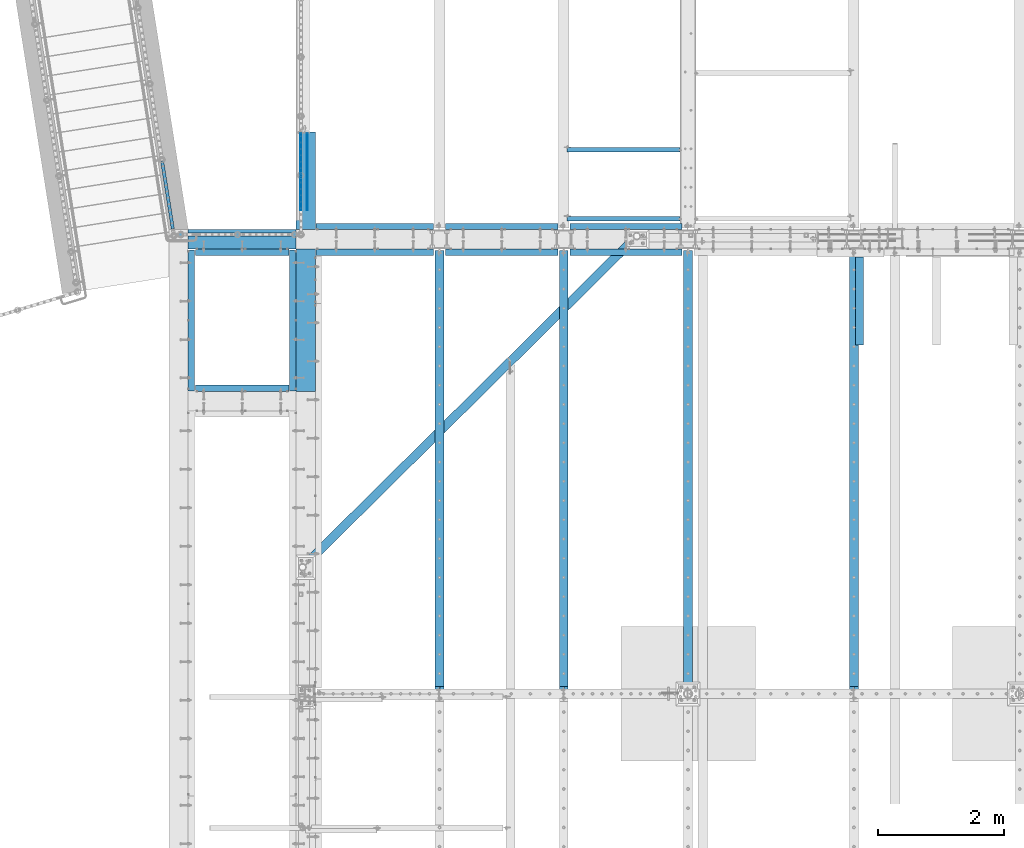
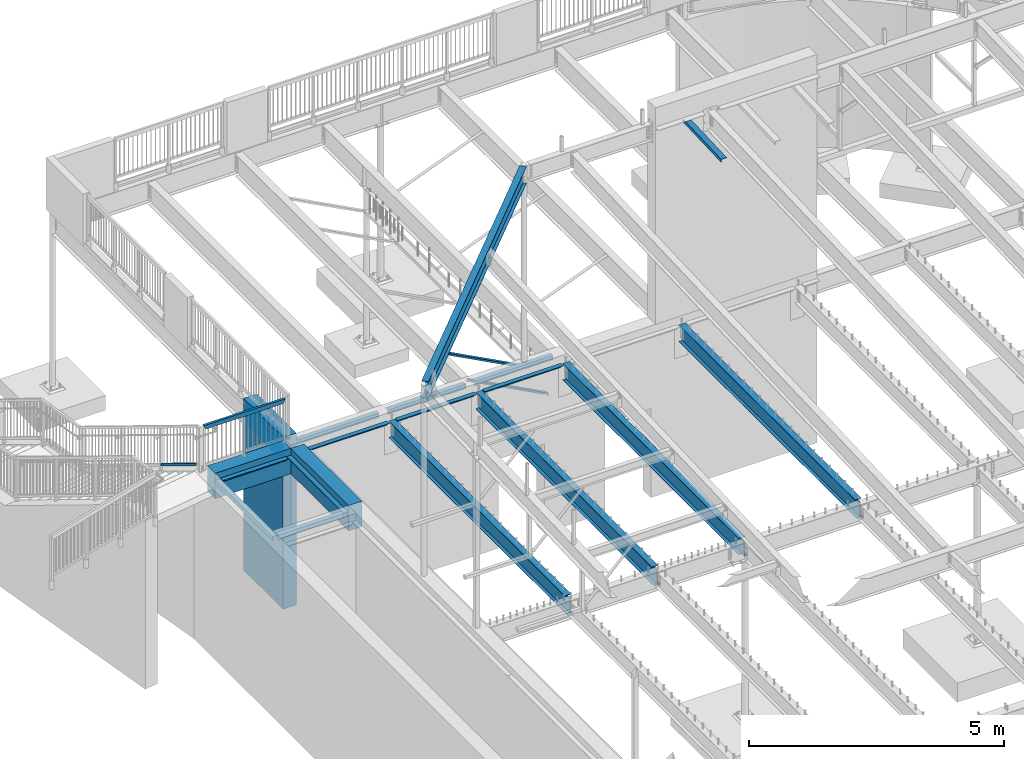
# One storey, part 319 of 975: 34 beams, 1 member.
"""IFC2X3 building model written with IfcOpenShell, lengths in millimetres."""

from ifc_helpers import new_model, si_unit, frame, origin_with_axes, place, context, subcontext, project, spatial, faceted_brep, material, type_object, element, save


model = new_model("IFC2X3")

# Units and contexts
model_context = context("Model", 3, precision=1e-05, world=origin_with_axes())
body_context = subcontext(model_context, "Body", "Model", "MODEL_VIEW")
ifc_project = project(units=[si_unit("LENGTHUNIT", "METRE", prefix="MILLI"), si_unit("AREAUNIT", "SQUARE_METRE"), si_unit("VOLUMEUNIT", "CUBIC_METRE"), si_unit("MASSUNIT", "GRAM", prefix="KILO"), si_unit("TIMEUNIT", "SECOND"), si_unit("PLANEANGLEUNIT", "RADIAN"), si_unit("SOLIDANGLEUNIT", "STERADIAN"), si_unit("THERMODYNAMICTEMPERATUREUNIT", "DEGREE_CELSIUS"), si_unit("LUMINOUSINTENSITYUNIT", "LUMEN")], contexts=[model_context])

# Site, building, storey
site_placement = place(None, origin_with_axes())
site = spatial("IfcSite", under=ifc_project, at=site_placement, CompositionType="ELEMENT")
building_placement = place(site_placement, origin_with_axes())
building = spatial("IfcBuilding", under=site, at=building_placement, Name="Undefined", CompositionType="ELEMENT")
storey_placement = place(building_placement, origin_with_axes())
storey = spatial("IfcBuildingStorey", under=building, at=storey_placement, Name="Undefined", CompositionType="ELEMENT", Elevation=0.0)

# Beams
ifc_material_1 = material(Name="STEEL/A36")
beam_type_1 = type_object("IfcBeamType", Name="L3X3X3/16", PredefinedType="NOTDEFINED")
for number, where, z_axis, x_axis, name in (
    (1, (8064.5, 22016.24375, 2870.2), (-0.999999999999998, 6.90000001668524e-08, 0.0), (0.0, 0.0, 1.0), "ANGLE"),
    (2, (8064.5, 20924.04375, 2870.2), (-0.999999999999998, 6.90000001668524e-08, 0.0), (0.0, 0.0, 1.0), "ANGLE"),
):
    element("IfcBeam", number, at=place(storey_placement, frame(where, z_axis=z_axis, x_axis=x_axis)), inside=storey, type_object=beam_type_1, material=ifc_material_1, Name=name, ObjectType="L3X3X3/16", context=body_context, shape_type="Brep", body=[
        faceted_brep([(46.1799589858119, 38.0999999999985, 38.1000000000004), (46.1799589858119, 33.3375000000015, 38.1000000000004), (972.720343066658, 33.3375000000015, 1789.57301067668), (972.720343066658, 38.0999999999985, 1789.57301067668), (26.0603826014149, 38.0999999999985, 0.0672324894812846), (26.0603826014149, 33.3375000000015, 0.0672324894812846), (89.2065642251332, 38.0999999999985, -33.3374999984389), (89.2065642251332, 33.3375000000015, -33.3374999984389), (1035.86652469034, 33.3375000000015, 1756.16827818882), (89.2065642281518, -38.0999999999985, -33.3374999999996), (1035.86652469042, -38.0999999999985, 1756.16827818877), (25.4000000000001, -38.0999999999985, -33.3374999999996), (25.4000000000001, -38.0999999999985, -38.1000000000004), (92.0750045776413, -38.0999999999985, -38.1000000000004), (1040.07627013201, -38.0999999999985, 1753.94129602291), (92.0750045776413, 38.0999999999985, -38.1000000000004), (25.4000000000001, 38.0999999999985, -38.1000000000004), (1040.07627013201, 38.0999999999985, 1753.94129602291), (25.4000000000001, 38.0999999999985, -33.337499282643), (25.4000000000001, 33.3375000000015, -33.3374999999996)], [[[0, 1, 2, 3]], [[1, 0, 4, 5]], [[5, 4, 6, 7]], [[1, 5, 7, 8, 2]], [[7, 9, 10, 8]], [[9, 11, 12, 13, 14, 10]], [[15, 13, 12, 16]], [[13, 15, 17, 14]], [[3, 2, 8, 10, 14, 17]], [[15, 16, 18, 6, 4, 0, 3, 17]], [[7, 6, 18, 19]], [[16, 12, 11, 19, 18]], [[9, 7, 19, 11]]]),
    ])

# Member
ifc_material_2 = material()
member_type = type_object("IfcMemberType", Name="HSS2X2X.188_TUBES", PredefinedType="NOTDEFINED")
member_placement = place(storey_placement, frame((64.2711378482237, 20753.3422070973, 4156.0636980397), z_axis=(0.987688352468583, 0.156434390074216, -6.09999983468464e-08), x_axis=(-0.136949714005939, 0.864666463037498, -0.48331840802096)))
element("IfcMember", 3, at=member_placement, inside=storey, type_object=member_type, material=ifc_material_2, Name="HANDRAIL", ObjectType="HSS2X2X.188_TUBES", context=body_context, shape_type="Brep", body=[
    faceted_brep([(1.22733805137614, 20.6375000000317, -20.6374999999935), (11.864264413236, -20.6375000000044, -20.6375000000012), (1260.85730620972, -20.6375000006847, -20.6375000002959), (1238.07006599417, 20.6374999993604, -20.6375000002859), (11.8642640556318, -20.6375000000298, 20.6374999999916), (1260.8573061982, -20.6375000007101, 20.637499999697), (1.2273376937701, 20.6375000000044, 20.6374999999994), (1238.07006598265, 20.6374999993313, 20.637499999707), (0.0, 25.3999999999724, -25.4000000000342), (0.0, 25.400000000016, 25.4000000000196), (1235.44076903337, 25.3999999993339, 25.3999999997081), (1235.44076904756, 25.3999999993666, -25.4000000002829), (13.0916016715055, -25.4000000000397, 25.3999999999892), (1263.48660314481, -25.4000000007181, 25.399999999695), (13.0916021116373, -25.4000000000051, -25.4000000000015), (1263.48660315901, -25.4000000006854, -25.4000000002961)], [[[0, 1, 2, 3]], [[1, 4, 5, 2]], [[4, 6, 7, 5]], [[6, 0, 3, 7]], [[8, 9, 10, 11]], [[9, 12, 13, 10]], [[12, 14, 15, 13]], [[14, 8, 11, 15]], [[13, 15, 11, 10], [5, 7, 3, 2]], [[14, 12, 9, 8], [6, 4, 1, 0]]]),
])

# Beams
beam_type_2 = type_object("IfcBeamType", Name="HSS2X4X.188_TUBES", PredefinedType="NOTDEFINED")
beam_1_placement = place(storey_placement, frame((160.888332432286, 20672.4249713359, 5054.60000302264), z_axis=(0.0, 0.0, 1.0), x_axis=(1.0, 0.0, 0.0)))
element("IfcBeam", 4, at=beam_1_placement, inside=storey, type_object=beam_type_2, material=ifc_material_2, Name="HANDRAIL", ObjectType="HSS2X4X.188_TUBES", context=body_context, shape_type="Brep", body=[
    faceted_brep([(48.4187519319242, 20.6374999999716, -46.0375000000158), (48.4187519525875, -20.6375000000262, -46.0375000000158), (1806.21591102758, -20.6375000011067, -46.0375000006106), (1806.21591812686, 20.6374999988948, -46.0375000006106), (2.38125022328143, -20.6375000000007, 46.0374999999995), (1852.253417019, -20.6375000011321, 46.0374999993737), (2.38125020261811, 20.6375000000007, 46.0374999999995), (1852.25342411827, 20.6374999988693, 46.0374999993728), (50.8000020189868, 25.3999999999687, -50.8000000000166), (1.10786999130141e-07, 25.4000000000015, 50.8000000000011), (1854.63467524732, 25.3999999988628, 50.7999999993726), (1803.8346686361, 25.3999999988955, -50.8000000006105), (1.36218801571886e-07, -25.4000000000015, 50.8000000000011), (1854.63466650975, -25.4000000011365, 50.7999999993726), (50.8000020444186, -25.4000000000306, -50.8000000000166), (1803.83465989853, -25.4000000011038, -50.8000000006105)], [[[0, 1, 2, 3]], [[1, 4, 5, 2]], [[4, 6, 7, 5]], [[6, 0, 3, 7]], [[8, 9, 10, 11]], [[9, 12, 13, 10]], [[12, 14, 15, 13]], [[14, 8, 11, 15]], [[13, 15, 11, 10], [5, 7, 3, 2]], [[14, 12, 9, 8], [6, 4, 1, 0]]]),
])
beam_type_3 = type_object("IfcBeamType", Name="L4X4X5/16", PredefinedType="NOTDEFINED")
for number, where, z_axis, x_axis, name in (
    (5, (8134.35000000049, 20799.4249996637, 3886.2), (0.0, 1.0, 0.0), (-0.999999999999998, 6.90000001668524e-08, 0.0), "LEDGER_ANGLE"),
    (6, (6164.79172920556, 20799.4249996637, 3886.2), (0.0, 1.0, 0.0), (-0.999999999999998, 6.90000001668524e-08, 0.0), "LEDGER_ANGLE"),
):
    element("IfcBeam", number, at=place(storey_placement, frame(where, z_axis=z_axis, x_axis=x_axis)), inside=storey, type_object=beam_type_3, material=ifc_material_1, Name=name, ObjectType="L4X4X5/16", context=body_context, shape_type="Brep", body=[
        faceted_brep([(-1.90993887372315e-11, 50.8000000000002, -50.8), (2.00088834390044e-11, 50.8000000000002, 50.8), (1779.05827079733, 50.8000000000002, 50.7999999999993), (1779.05827079733, 50.8000000000002, -50.7999999999993), (2.00088834390044e-11, 42.8625000000002, 50.8), (1779.05827079733, 42.8625000000002, 50.7999999999993), (-1.63709046319127e-11, 42.8625000000002, -42.8625), (1779.05827079733, 42.8625000000002, -42.8624999999993), (-1.63709046319127e-11, -50.8000000000002, -42.8625), (1779.05827079733, -50.8000000000002, -42.8624999999993), (-1.90993887372315e-11, -50.8000000000002, -50.8), (1779.05827079733, -50.8000000000002, -50.7999999999993)], [[[0, 1, 2, 3]], [[1, 4, 5, 2]], [[4, 6, 7, 5]], [[6, 8, 9, 7]], [[8, 10, 11, 9]], [[10, 0, 3, 11]], [[5, 7, 9, 11, 3, 2]], [[10, 8, 6, 4, 1, 0]]]),
    ])
beam_2_placement = place(storey_placement, frame((4195.2334584078, 20799.4249996637, 3886.2), z_axis=(0.0, 1.0, 0.0), x_axis=(-0.999999999999998, 6.90000001668524e-08, 0.0)))
element("IfcBeam", 7, at=beam_2_placement, inside=storey, type_object=beam_type_3, material=ifc_material_1, Name="LEDGER_ANGLE", ObjectType="L4X4X5/16", context=body_context, shape_type="Brep", body=[
    faceted_brep([(-1.90993887372315e-11, 50.8000000000002, -50.8), (2.00088834390044e-11, 50.8000000000002, 50.8), (1861.60845841014, 50.8000000000002, 50.7999999999993), (1861.60845841014, 50.8000000000002, -50.7999999999993), (2.00088834390044e-11, 42.8625000000002, 50.8), (1861.60845841014, 42.8625000000002, 50.7999999999993), (-1.63709046319127e-11, 42.8625000000002, -42.8625), (1861.60845841014, 42.8625000000002, -42.8624999999993), (-1.63709046319127e-11, -50.8000000000002, -42.8625), (1861.60845841014, -50.8000000000002, -42.8624999999993), (-1.90993887372315e-11, -50.8000000000002, -50.8), (1861.60845841014, -50.8000000000002, -50.7999999999993)], [[[0, 1, 2, 3]], [[1, 4, 5, 2]], [[4, 6, 7, 5]], [[6, 8, 9, 7]], [[8, 10, 11, 9]], [[10, 0, 3, 11]], [[5, 7, 9, 11, 3, 2]], [[10, 8, 6, 4, 1, 0]]]),
])
for number, where, z_axis, x_axis, name in (
    (8, (6355.29172920315, 20393.025, 3886.2), (0.0, -1.0, 0.0), (1.0, 0.0, 0.0), "LEDGER_ANGLE"),
    (9, (4385.73345840823, 20393.025, 3886.2), (0.0, -1.0, 0.0), (1.0, 0.0, 0.0), "LEDGER_ANGLE"),
):
    element("IfcBeam", number, at=place(storey_placement, frame(where, z_axis=z_axis, x_axis=x_axis)), inside=storey, type_object=beam_type_3, material=ifc_material_1, Name=name, ObjectType="L4X4X5/16", context=body_context, shape_type="Brep", body=[
        faceted_brep([(-1.90993887372315e-11, 50.8000000000002, -50.8), (2.00088834390044e-11, 50.8000000000002, 50.8), (1779.05827079733, 50.8000000000002, 50.7999999999993), (1779.05827079733, 50.8000000000002, -50.7999999999993), (2.00088834390044e-11, 42.8625000000002, 50.8), (1779.05827079733, 42.8625000000002, 50.7999999999993), (-1.63709046319127e-11, 42.8625000000002, -42.8625), (1779.05827079733, 42.8625000000002, -42.8624999999993), (-1.63709046319127e-11, -50.8000000000002, -42.8625), (1779.05827079733, -50.8000000000002, -42.8624999999993), (-1.90993887372315e-11, -50.8000000000002, -50.8), (1779.05827079733, -50.8000000000002, -50.7999999999993)], [[[0, 1, 2, 3]], [[1, 4, 5, 2]], [[4, 6, 7, 5]], [[6, 8, 9, 7]], [[8, 10, 11, 9]], [[10, 0, 3, 11]], [[5, 7, 9, 11, 3, 2]], [[10, 8, 6, 4, 1, 0]]]),
    ])
beam_3_placement = place(storey_placement, frame((2333.62499999766, 20393.025, 3886.2), z_axis=(0.0, -1.0, 0.0), x_axis=(1.0, 0.0, 0.0)))
element("IfcBeam", 10, at=beam_3_placement, inside=storey, type_object=beam_type_3, material=ifc_material_1, Name="LEDGER_ANGLE", ObjectType="L4X4X5/16", context=body_context, shape_type="Brep", body=[
    faceted_brep([(-1.90993887372315e-11, 50.8000000000002, -50.8), (2.00088834390044e-11, 50.8000000000002, 50.8), (1861.60845841014, 50.8000000000002, 50.7999999999993), (1861.60845841014, 50.8000000000002, -50.7999999999993), (2.00088834390044e-11, 42.8625000000002, 50.8), (1861.60845841014, 42.8625000000002, 50.7999999999993), (-1.63709046319127e-11, 42.8625000000002, -42.8625), (1861.60845841014, 42.8625000000002, -42.8624999999993), (-1.63709046319127e-11, -50.8000000000002, -42.8625), (1861.60845841014, -50.8000000000002, -42.8624999999993), (-1.90993887372315e-11, -50.8000000000002, -50.8), (1861.60845841014, -50.8000000000002, -50.7999999999993)], [[[0, 1, 2, 3]], [[1, 4, 5, 2]], [[4, 6, 7, 5]], [[6, 8, 9, 7]], [[8, 10, 11, 9]], [[10, 0, 3, 11]], [[5, 7, 9, 11, 3, 2]], [[10, 8, 6, 4, 1, 0]]]),
])
for number, where, z_axis, x_axis, name in (
    (11, (1901.82501000529, 18234.0249997141, 3835.4), (0.0, 1.0, 0.0), (-0.999999999999998, 6.90000001668524e-08, 0.0), "LEDGER_ANGLE"),
    (12, (419.099990636183, 20393.0249999496, 3835.4), (0.0, -1.0, 0.0), (1.0, 0.0, 0.0), "LEDGER_ANGLE"),
):
    element("IfcBeam", number, at=place(storey_placement, frame(where, z_axis=z_axis, x_axis=x_axis)), inside=storey, type_object=beam_type_3, material=ifc_material_1, Name=name, ObjectType="L4X4X5/16", context=body_context, shape_type="Brep", body=[
        faceted_brep([(-1.90993887372315e-11, 50.8000000000002, -50.8), (2.00088834390044e-11, 50.8000000000002, 50.8), (1482.7250193691, 50.8000000000002, 50.8000000000002), (1482.7250193691, 50.8000000000002, -50.8000000000002), (2.00088834390044e-11, 42.8625000000002, 50.8), (1482.7250193691, 42.8625000000002, 50.8000000000002), (-1.63709046319127e-11, 42.8625000000002, -42.8625), (1482.7250193691, 42.8625000000002, -42.8625000000002), (-1.63709046319127e-11, -50.8000000000002, -42.8625), (1482.7250193691, -50.8000000000002, -42.8625000000002), (-1.90993887372315e-11, -50.8000000000002, -50.8), (1482.7250193691, -50.8000000000002, -50.8000000000002)], [[[0, 1, 2, 3]], [[1, 4, 5, 2]], [[4, 6, 7, 5]], [[6, 8, 9, 7]], [[8, 10, 11, 9]], [[10, 0, 3, 11]], [[5, 7, 9, 11, 3, 2]], [[10, 8, 6, 4, 1, 0]]]),
    ])
for number, where, z_axis, x_axis, name in (
    (13, (1965.32501046287, 20431.1250003557, 3835.4), (-0.999999999999998, 6.90000001668524e-08, 0.0), (0.0, -1.0, 0.0), "LEDGER_ANGLE"),
    (14, (355.600005648879, 18195.9250003556, 3835.4), (1.0, 0.0, 0.0), (0.0, 1.0, 0.0), "LEDGER_ANGLE"),
):
    element("IfcBeam", number, at=place(storey_placement, frame(where, z_axis=z_axis, x_axis=x_axis)), inside=storey, type_object=beam_type_3, material=ifc_material_1, Name=name, ObjectType="L4X4X5/16", context=body_context, shape_type="Brep", body=[
        faceted_brep([(-1.90993887372315e-11, 50.8000000000002, -50.8), (2.00088834390044e-11, 50.8000000000002, 50.8), (2235.20000000007, 50.8000000000002, 50.7999999998344), (2235.20000000002, 50.8000000000002, -50.8000000001655), (2.00088834390044e-11, 42.8625000000002, 50.8), (2235.20000000007, 42.8625000000002, 50.7999999998344), (-1.63709046319127e-11, 42.8625000000002, -42.8625), (2235.20000000003, 42.8625000000002, -42.8625000001655), (-1.63709046319127e-11, -50.8000000000002, -42.8625), (2235.20000000003, -50.8000000000002, -42.8625000001655), (-1.90993887372315e-11, -50.8000000000002, -50.8), (2235.20000000002, -50.8000000000002, -50.8000000001655)], [[[0, 1, 2, 3]], [[1, 4, 5, 2]], [[4, 6, 7, 5]], [[6, 8, 9, 7]], [[8, 10, 11, 9]], [[10, 0, 3, 11]], [[5, 7, 9, 11, 3, 2]], [[10, 8, 6, 4, 1, 0]]]),
    ])
beam_type_4 = type_object("IfcBeamType", Name="L5X3X5/16", PredefinedType="NOTDEFINED")
beam_4_placement = place(storey_placement, frame((10945.8125, 18922.6835815429, 8738.42095184572), z_axis=(1.0, 0.0, 0.0), x_axis=(0.0, 0.999153014665285, 0.0411491589862177)))
element("IfcBeam", 15, at=beam_4_placement, inside=storey, type_object=beam_type_4, material=ifc_material_1, Name="ANGLE", ObjectType="L5X3X5/16", context=body_context, shape_type="Brep", body=[
    faceted_brep([(1395.30358400897, 38.0999999993073, 63.5), (1394.97671549211, 30.1624999993064, 63.5), (1394.97670561824, 30.1624999993055, -55.5625), (1394.97670495998, 30.1624990542159, -63.5), (1395.30357345898, 38.0999999993073, -63.5), (1501.24906497065, 25.7857737940658, -55.5625), (1501.24906431239, 25.785773821176, -63.5), (1513.41947380123, 12.5737820912245, -55.5625), (1513.41947314297, 12.5737821183347, -63.5), (1511.34756340183, -38.1000000007598, -55.5625), (1511.34756274358, -38.1000000007589, -63.5), (5.0931703299284e-11, -38.0999999999999, -63.5000000000255), (2.27373675443232e-12, -38.1000000000313, -55.5624999999873), (3.41060513164848e-12, 30.1624999999367, -55.5625000000091), (-3.63797880709171e-12, 30.1625000000404, 63.4999999999909), (-4.72937244921923e-11, 38.0999999999999, 63.5000000000182), (5.0931703299284e-11, 38.0999999999999, -63.5000000000255)], [[[0, 1, 2, 3, 4]], [[5, 6, 3, 2]], [[7, 8, 6, 5]], [[9, 10, 8, 7]], [[11, 12, 13, 14, 15, 16]], [[14, 13, 2, 1]], [[15, 14, 1, 0]], [[16, 15, 0, 4]], [[11, 16, 4, 3, 6, 8, 10]], [[12, 11, 10, 9]], [[2, 13, 12, 9, 7, 5]]]),
])
ifc_material_3 = material(Name="STEEL/A496")
beam_type_5 = type_object("IfcBeamType", Name="#6 DBA", PredefinedType="NOTDEFINED")
for number, where, z_axis, x_axis, name in (
    (16, (2092.325, 22278.975, 3808.4125), (-0.999999999999998, 6.90000001668524e-08, 0.0), (0.0, -1.0, 0.0), "ROD"),
    (17, (2193.925, 22278.975, 3808.4125), (-0.999999999999998, 6.90000001668524e-08, 0.0), (0.0, -1.0, 0.0), "ROD"),
    (18, (2092.325, 22278.975, 3719.5125), (-0.999999999999998, 6.90000001668524e-08, 0.0), (0.0, -1.0, 0.0), "ROD"),
    (19, (2193.925, 22278.975, 3719.5125), (-0.999999999999998, 6.90000001668524e-08, 0.0), (0.0, -1.0, 0.0), "ROD"),
    (20, (2092.325, 22278.975, 3630.6125), (-0.999999999999998, 6.90000001668524e-08, 0.0), (0.0, -1.0, 0.0), "ROD"),
    (21, (2193.925, 22278.975, 3630.6125), (-0.999999999999998, 6.90000001668524e-08, 0.0), (0.0, -1.0, 0.0), "ROD"),
    (22, (2092.325, 22278.975, 3541.7125), (-0.999999999999998, 6.90000001668524e-08, 0.0), (0.0, -1.0, 0.0), "ROD"),
    (23, (2193.925, 22278.975, 3541.7125), (-0.999999999999998, 6.90000001668524e-08, 0.0), (0.0, -1.0, 0.0), "ROD"),
    (24, (2092.325, 22278.975, 3452.8125), (-0.999999999999998, 6.90000001668524e-08, 0.0), (0.0, -1.0, 0.0), "ROD"),
    (25, (2193.925, 22278.975, 3452.8125), (-0.999999999999998, 6.90000001668524e-08, 0.0), (0.0, -1.0, 0.0), "ROD"),
    (26, (2092.325, 22278.975, 3897.3125), (-0.999999999999998, 6.90000001668524e-08, 0.0), (0.0, -1.0, 0.0), "ROD"),
    (27, (2193.925, 22278.975, 3897.3125), (-0.999999999999998, 6.90000001668524e-08, 0.0), (0.0, -1.0, 0.0), "ROD"),
):
    element("IfcBeam", number, at=place(storey_placement, frame(where, z_axis=z_axis, x_axis=x_axis)), inside=storey, type_object=beam_type_5, material=ifc_material_3, Name=name, ObjectType="#6 DBA", context=body_context, shape_type="Brep", body=[
        faceted_brep([(0.0, -6.34999999998763, -3.63797880709171e-12), (0.0, -4.49012806052269, -4.49012806054634), (1219.19983372321, -4.49012806053543, -4.49012805836537), (1219.19983372321, -6.35000000000036, 2.16823536902666e-09), (0.0, 7.27595761418343e-12, -6.35000000000764), (1219.19983372321, 0.0, -6.34999999783395), (0.0, 4.49012806053724, -4.49012806053906), (1219.19983372321, 4.49012806053543, -4.49012805836537), (0.0, 6.34999999999491, 5.45696821063757e-12), (1219.19983372321, 6.35000000000036, 2.16823536902666e-09), (0.0, 4.49012806052633, 4.49012806054634), (1219.19983372321, 4.49012806053543, 4.49012806270184), (0.0, 0.0, 6.35000000000764), (1219.19983372321, 0.0, 6.35000000216678), (0.0, -4.49012806053361, 4.49012806053543), (1219.19983372321, -4.49012806053543, 4.49012806270184)], [[[0, 1, 2, 3]], [[1, 4, 5, 2]], [[4, 6, 7, 5]], [[6, 8, 9, 7]], [[8, 10, 11, 9]], [[10, 12, 13, 11]], [[12, 14, 15, 13]], [[14, 0, 3, 15]], [[5, 7, 9, 11, 13, 15, 3, 2]], [[14, 12, 10, 8, 6, 4, 1, 0]]]),
    ])
ifc_material_4 = material(Name="STEEL/A992")
beam_type_6 = type_object("IfcBeamType", Name="W16X31", PredefinedType="NOTDEFINED")
beam_5_placement = place(storey_placement, frame((2122.11357014384, 15403.0964987704, 8409.08213836788), z_axis=(0.0217673511953544, 0.0215586767925997, -0.99953059276687), x_axis=(0.710170716086953, 0.703362609086119, 0.0306364840037512)))
element("IfcBeam", 28, at=beam_5_placement, inside=storey, type_object=beam_type_6, material=ifc_material_4, Name="BEAM", ObjectType="W16X31", context=body_context, shape_type="Brep", body=[
    faceted_brep([(81.5228372901202, -69.8499999999876, -190.500000000162), (81.8634451023827, -69.849999999984, -201.612500000172), (7379.80630373897, -69.8500000049771, -201.612499998078), (7379.4656959267, -69.8500000049771, -190.499999998068), (81.5228373026312, -3.17500000000291, -190.500000000142), (7379.46569593922, -3.17500000499422, -190.499999998046), (69.8448551679121, -3.17500000009568, 190.500000000183), (7367.7877138045, -3.1750000050888, 190.500000002278), (69.8448551554029, -69.8500000000804, 190.500000000161), (7367.78771379199, -69.8500000050717, 190.500000002257), (69.5042473431386, -69.8500000000822, 201.612500000171), (7367.44710597973, -69.8500000050753, 201.612500002267), (69.5042473693538, 69.8499999998821, 201.612500000217), (7367.44710600594, 69.8499999948945, 201.612500002311), (69.8448551816164, 69.8499999998876, 190.500000000205), (7367.7877138182, 69.8499999948963, 190.500000002301), (69.8448551691054, 3.17499999990287, 190.500000000185), (7367.78771380569, 3.17499999491156, 190.500000002279), (81.5228373038226, 3.174999999992, -190.500000000142), (7379.46569594041, 3.17499999500433, -190.499999998045), (81.5228373163354, 69.8499999999767, -190.500000000118), (7379.46569595292, 69.8499999949854, -190.499999998025), (81.8634451285998, 69.8499999999822, -201.612500000127), (7379.80630376518, 69.8499999949909, -201.612499998033)], [[[0, 1, 2, 3]], [[4, 0, 3, 5]], [[6, 4, 5, 7]], [[8, 6, 7, 9]], [[10, 8, 9, 11]], [[12, 10, 11, 13]], [[14, 12, 13, 15]], [[16, 14, 15, 17]], [[18, 16, 17, 19]], [[20, 18, 19, 21]], [[1, 0, 4, 6, 8, 10, 12, 14, 16, 18, 20, 22]], [[1, 22, 23, 2]], [[19, 17, 15, 13, 11, 9, 7, 5, 3, 2, 23, 21]], [[22, 20, 21, 23]]]),
])
beam_type_7 = type_object("IfcBeamType", Name="W16X26", PredefinedType="NOTDEFINED")
beam_6_placement = place(storey_placement, frame((10858.5, 13392.15, 3736.975), z_axis=(0.0, 0.0, 1.0), x_axis=(0.0, 1.0, 0.0)))
element("IfcBeam", 29, at=beam_6_placement, inside=storey, type_object=beam_type_7, material=ifc_material_4, Name="BEAM", ObjectType="W16X26", context=body_context, shape_type="Brep", body=[
    faceted_brep([(29.368749999996, -3.17499999999927, -190.5), (29.368749999996, -69.8499999999985, -190.5), (7026.275, -69.8500000000004, -190.5), (7026.275, -3.17499999999927, -190.5), (29.368749999996, -69.8499999999985, -200.025), (7026.275, -69.8500000000004, -200.025), (29.368749999996, 69.8499999999985, -200.025), (7026.275, 69.8500000000004, -200.025), (29.368749999996, 69.8499999999985, -190.5), (7026.275, 69.8500000000004, -190.5), (7026.275, 3.17499999999927, -190.5), (7026.275, 3.17499999999927, 190.5), (7026.275, 69.8500000000004, 190.5), (7026.275, 69.8500000000004, 200.025), (7026.275, -69.8500000000004, 200.025), (7026.275, -69.8500000000004, 190.5), (7026.275, -3.17499999999927, 190.5), (29.368749999996, 3.17499999999927, -190.5), (110.428829708775, -3.17499999999927, 175.591729922588), (110.428829708775, 3.17499999999927, 175.591729922588), (105.568750190729, 3.17499999999927, 174.625), (105.568750190729, -3.17499999999927, 174.625), (114.549006176929, -3.17499999999927, 178.344743823066), (114.549006176929, 3.17499999999927, 178.344743823066), (117.302020077406, -3.17499999999927, 182.46492029122), (117.302020077406, 3.17499999999927, 182.46492029122), (118.268749999994, -3.17499999999927, 187.324999809266), (118.268749999994, 3.17499999999927, 187.324999809266), (29.368749999996, 3.17499999999927, 174.625), (118.268749999994, 3.17499999999927, 190.5), (118.268749999994, 69.8499999999985, 190.5), (118.268749999994, 69.8499999999985, 200.025), (118.268749999994, -69.8499999999985, 200.024999810586), (118.268749999994, -69.8499999999985, 190.5), (118.268749999994, -3.17499999999927, 190.5), (29.368749999996, -3.17499999999927, 174.625)], [[[0, 1, 2, 3]], [[1, 4, 5, 2]], [[4, 6, 7, 5]], [[6, 8, 9, 7]], [[10, 11, 12, 13, 14, 15, 16, 3, 2, 5, 7, 9]], [[8, 17, 10, 9]], [[18, 19, 20, 21]], [[22, 23, 19, 18]], [[24, 25, 23, 22]], [[26, 27, 25, 24]], [[11, 10, 17, 28, 20, 19, 23, 25, 27, 29]], [[12, 11, 29, 30]], [[13, 12, 30, 31]], [[14, 13, 31, 32]], [[15, 14, 32, 33]], [[16, 15, 33, 34]], [[32, 31, 30, 29, 27, 26, 34, 33]], [[24, 22, 18, 21, 35, 0, 3, 16, 34, 26]], [[17, 8, 6, 4, 1, 0, 35, 28]], [[21, 20, 28, 35]]]),
])
beam_7_placement = place(storey_placement, frame((8229.6, 13392.15, 3736.975), z_axis=(0.0, 0.0, 1.0), x_axis=(0.0, 1.0, 0.0)))
element("IfcBeam", 30, at=beam_7_placement, inside=storey, type_object=beam_type_7, material=ifc_material_4, Name="BEAM", ObjectType="W16X26", context=body_context, shape_type="Brep", body=[
    faceted_brep([(29.368749999996, -3.17499999999927, -190.5), (29.368749999996, -69.8499999999985, -190.5), (7026.275, -69.8500000000004, -190.5), (7026.275, -3.17499999999927, -190.5), (29.368749999996, -69.8499999999985, -200.025), (7026.275, -69.8500000000004, -200.025), (7026.275, 3.17499999999927, -190.5), (7026.275, 3.17499999999927, 190.5), (7026.275, 69.8500000000004, 190.5), (7026.275, 69.8500000000004, 200.025), (7026.275, -69.8500000000004, 200.025), (7026.275, -69.8500000000004, 190.5), (7026.275, -3.17499999999927, 190.5), (7026.275, 69.8500000000004, -200.025), (7026.275, 69.8500000000004, -190.5), (124.618750000001, 69.8500000000004, -200.025), (124.618750000001, 69.8500000000004, -190.5), (124.618750000001, 3.77549991607884, -200.025), (124.618750000001, 3.77549991607884, -190.5), (29.3687499999996, 3.77549991607884, -200.025), (29.3687499999996, 3.77549991607884, -190.5), (29.368749999996, 3.17499999999927, -190.5), (110.428829708775, -3.17499999999927, 175.591729922588), (110.428829708775, 3.17499999999927, 175.591729922588), (105.568750190729, 3.17499999999927, 174.625), (105.568750190729, -3.17499999999927, 174.625), (114.549006176929, -3.17499999999927, 178.344743823066), (114.549006176929, 3.17499999999927, 178.344743823066), (117.302020077406, -3.17499999999927, 182.46492029122), (117.302020077406, 3.17499999999927, 182.46492029122), (118.268749999994, -3.17499999999927, 187.324999809266), (118.268749999994, 3.17499999999927, 187.324999809266), (29.368749999996, 3.17499999999927, 174.625), (118.268749999994, 3.17499999999927, 190.5), (118.268749999994, 69.8499999999985, 190.5), (118.268749999994, 69.8499999999985, 200.025), (118.268749999994, -69.8499999999985, 200.024999810586), (118.268749999994, -69.8499999999985, 190.5), (118.268749999994, -3.17499999999927, 190.5), (29.368749999996, -3.17499999999927, 174.625)], [[[0, 1, 2, 3]], [[1, 4, 5, 2]], [[6, 7, 8, 9, 10, 11, 12, 3, 2, 5, 13, 14]], [[14, 13, 15, 16]], [[16, 15, 17, 18]], [[13, 5, 4, 19, 17, 15]], [[18, 17, 19, 20]], [[21, 6, 14, 16, 18, 20]], [[22, 23, 24, 25]], [[26, 27, 23, 22]], [[28, 29, 27, 26]], [[30, 31, 29, 28]], [[7, 6, 21, 32, 24, 23, 27, 29, 31, 33]], [[8, 7, 33, 34]], [[9, 8, 34, 35]], [[10, 9, 35, 36]], [[11, 10, 36, 37]], [[12, 11, 37, 38]], [[36, 35, 34, 33, 31, 30, 38, 37]], [[28, 26, 22, 25, 39, 0, 3, 12, 38, 30]], [[21, 20, 19, 4, 1, 0, 39, 32]], [[25, 24, 32, 39]]]),
])
beam_8_placement = place(storey_placement, frame((6260.04172920507, 13392.15, 3736.975), z_axis=(0.0, 0.0, 1.0), x_axis=(0.0, 1.0, 0.0)))
element("IfcBeam", 31, at=beam_8_placement, inside=storey, type_object=beam_type_7, material=ifc_material_4, Name="BEAM", ObjectType="W16X26", context=body_context, shape_type="Brep", body=[
    faceted_brep([(29.368749999996, -3.17499999999927, -190.5), (29.368749999996, -69.8499999999985, -190.5), (7026.275, -69.8500000000004, -190.5), (7026.275, -3.17499999999927, -190.5), (29.368749999996, -69.8499999999985, -200.025), (7026.275, -69.8500000000004, -200.025), (29.368749999996, 69.8499999999985, -200.025), (7026.275, 69.8500000000004, -200.025), (29.368749999996, 69.8499999999985, -190.5), (7026.275, 69.8500000000004, -190.5), (7026.275, 3.17499999999927, -190.5), (7026.275, 3.17499999999927, 190.5), (7026.275, 69.8500000000004, 190.5), (7026.275, 69.8500000000004, 200.025), (7026.275, -69.8500000000004, 200.025), (7026.275, -69.8500000000004, 190.5), (7026.275, -3.17499999999927, 190.5), (29.368749999996, 3.17499999999927, -190.5), (110.428829708775, -3.17499999999927, 175.591729922588), (110.428829708775, 3.17499999999927, 175.591729922588), (105.568750190729, 3.17499999999927, 174.625), (105.568750190729, -3.17499999999927, 174.625), (114.549006176929, -3.17499999999927, 178.344743823066), (114.549006176929, 3.17499999999927, 178.344743823066), (117.302020077406, -3.17499999999927, 182.46492029122), (117.302020077406, 3.17499999999927, 182.46492029122), (118.268749999994, -3.17499999999927, 187.324999809266), (118.268749999994, 3.17499999999927, 187.324999809266), (29.368749999996, 3.17499999999927, 174.625), (118.268749999994, 3.17499999999927, 190.5), (118.268749999994, 69.8499999999985, 190.5), (118.268749999994, 69.8499999999985, 200.025), (118.268749999994, -69.8499999999985, 200.024999810586), (118.268749999994, -69.8499999999985, 190.5), (118.268749999994, -3.17499999999927, 190.5), (29.368749999996, -3.17499999999927, 174.625)], [[[0, 1, 2, 3]], [[1, 4, 5, 2]], [[4, 6, 7, 5]], [[6, 8, 9, 7]], [[10, 11, 12, 13, 14, 15, 16, 3, 2, 5, 7, 9]], [[8, 17, 10, 9]], [[18, 19, 20, 21]], [[22, 23, 19, 18]], [[24, 25, 23, 22]], [[26, 27, 25, 24]], [[11, 10, 17, 28, 20, 19, 23, 25, 27, 29]], [[12, 11, 29, 30]], [[13, 12, 30, 31]], [[14, 13, 31, 32]], [[15, 14, 32, 33]], [[16, 15, 33, 34]], [[32, 31, 30, 29, 27, 26, 34, 33]], [[24, 22, 18, 21, 35, 0, 3, 16, 34, 26]], [[17, 8, 6, 4, 1, 0, 35, 28]], [[21, 20, 28, 35]]]),
])
beam_9_placement = place(storey_placement, frame((4290.48345841015, 13392.15, 3736.975), z_axis=(0.0, 0.0, 1.0), x_axis=(0.0, 1.0, 0.0)))
element("IfcBeam", 32, at=beam_9_placement, inside=storey, type_object=beam_type_7, material=ifc_material_4, Name="BEAM", ObjectType="W16X26", context=body_context, shape_type="Brep", body=[
    faceted_brep([(29.368749999996, -3.17499999999927, -190.5), (29.368749999996, -69.8499999999985, -190.5), (7026.275, -69.8500000000004, -190.5), (7026.275, -3.17499999999927, -190.5), (29.368749999996, -69.8499999999985, -200.025), (7026.275, -69.8500000000004, -200.025), (29.368749999996, 69.8499999999985, -200.025), (7026.275, 69.8500000000004, -200.025), (29.368749999996, 69.8499999999985, -190.5), (7026.275, 69.8500000000004, -190.5), (7026.275, 3.17499999999927, -190.5), (7026.275, 3.17499999999927, 190.5), (7026.275, 69.8500000000004, 190.5), (7026.275, 69.8500000000004, 200.025), (7026.275, -69.8500000000004, 200.025), (7026.275, -69.8500000000004, 190.5), (7026.275, -3.17499999999927, 190.5), (29.368749999996, 3.17499999999927, -190.5), (110.428829708775, -3.17499999999927, 175.591729922588), (110.428829708775, 3.17499999999927, 175.591729922588), (105.568750190729, 3.17499999999927, 174.625), (105.568750190729, -3.17499999999927, 174.625), (114.549006176929, -3.17499999999927, 178.344743823066), (114.549006176929, 3.17499999999927, 178.344743823066), (117.302020077406, -3.17499999999927, 182.46492029122), (117.302020077406, 3.17499999999927, 182.46492029122), (118.268749999994, -3.17499999999927, 187.324999809266), (118.268749999994, 3.17499999999927, 187.324999809266), (29.368749999996, 3.17499999999927, 174.625), (118.268749999994, 3.17499999999927, 190.5), (118.268749999994, 69.8499999999985, 190.5), (118.268749999994, 69.8499999999985, 200.025), (118.268749999994, -69.8499999999985, 200.024999810586), (118.268749999994, -69.8499999999985, 190.5), (118.268749999994, -3.17499999999927, 190.5), (29.368749999996, -3.17499999999927, 174.625)], [[[0, 1, 2, 3]], [[1, 4, 5, 2]], [[4, 6, 7, 5]], [[6, 8, 9, 7]], [[10, 11, 12, 13, 14, 15, 16, 3, 2, 5, 7, 9]], [[8, 17, 10, 9]], [[18, 19, 20, 21]], [[22, 23, 19, 18]], [[24, 25, 23, 22]], [[26, 27, 25, 24]], [[11, 10, 17, 28, 20, 19, 23, 25, 27, 29]], [[12, 11, 29, 30]], [[13, 12, 30, 31]], [[14, 13, 31, 32]], [[15, 14, 32, 33]], [[16, 15, 33, 34]], [[32, 31, 30, 29, 27, 26, 34, 33]], [[24, 22, 18, 21, 35, 0, 3, 16, 34, 26]], [[17, 8, 6, 4, 1, 0, 35, 28]], [[21, 20, 28, 35]]]),
])
ifc_material_5 = material(Name="CONCRETE/5000")
beam_type_8 = type_object("IfcBeamType", PredefinedType="NOTDEFINED")
beam_10_placement = place(storey_placement, frame((2168.525, 20748.625, 2057.4), z_axis=(0.0, 0.0, 1.0), x_axis=(0.0, 1.0, 0.0)))
element("IfcBeam", 33, at=beam_10_placement, inside=storey, type_object=beam_type_8, material=ifc_material_5, Name="WALL", context=body_context, shape_type="Brep", body=[
    faceted_brep([(0.0, 152.399999999998, -2057.4), (0.0, 152.399999999998, 2057.4), (1549.4, 152.4, 2057.4), (1549.4, 152.4, -2057.4), (-4.33680868994202e-19, -152.400000000009, 2057.4), (1549.4, -152.4, 2057.4), (-4.33680868994202e-19, -152.400000000009, -2057.4), (1549.4, -152.4, -2057.4)], [[[0, 1, 2, 3]], [[1, 4, 5, 2]], [[4, 6, 7, 5]], [[6, 0, 3, 7]], [[5, 7, 3, 2]], [[6, 4, 1, 0]]]),
])
beam_type_9 = type_object("IfcBeamType", PredefinedType="NOTDEFINED")
beam_11_placement = place(storey_placement, frame((2168.525, 20443.825, 3733.8), z_axis=(0.0, 0.0, 1.0), x_axis=(0.0, -1.0, 0.0)))
element("IfcBeam", 34, at=beam_11_placement, inside=storey, type_object=beam_type_9, material=ifc_material_5, Name="WALL", context=body_context, shape_type="Brep", body=[
    faceted_brep([(-2.00088834390044e-11, 152.400000000001, -304.8), (-2.00088834390044e-11, 152.400000000001, 304.8), (2260.6, 152.4, 304.8), (2260.6, 152.4, -304.8), (1.90993887372315e-11, -152.400000000001, 304.8), (2260.6, -152.4, 304.8), (1.90993887372315e-11, -152.400000000001, -304.8), (2260.6, -152.4, -304.8)], [[[0, 1, 2, 3]], [[1, 4, 5, 2]], [[4, 6, 7, 5]], [[6, 0, 3, 7]], [[5, 7, 3, 2]], [[6, 4, 1, 0]]]),
])
beam_12_placement = place(storey_placement, frame((304.800000609604, 20596.225, 3733.8), z_axis=(0.0, 0.0, 1.0), x_axis=(1.0, 0.0, 0.0)))
element("IfcBeam", 35, at=beam_12_placement, inside=storey, type_object=beam_type_9, material=ifc_material_5, Name="WALL", context=body_context, shape_type="Brep", body=[
    faceted_brep([(-2.00088834390044e-11, 152.400000000001, -304.8), (-2.00088834390044e-11, 152.400000000001, 304.8), (1711.3249993904, 152.400000000001, 304.8), (1711.3249993904, 152.400000000001, -304.8), (1.90993887372315e-11, -152.400000000001, 304.8), (1711.3249993904, -152.400000000001, 304.8), (1.90993887372315e-11, -152.400000000001, -304.8), (1711.3249993904, -152.400000000001, -304.8)], [[[0, 1, 2, 3]], [[1, 4, 5, 2]], [[4, 6, 7, 5]], [[6, 0, 3, 7]], [[5, 7, 3, 2]], [[6, 4, 1, 0]]]),
])

save(model, "model.ifc")
